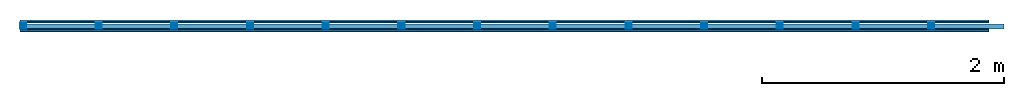
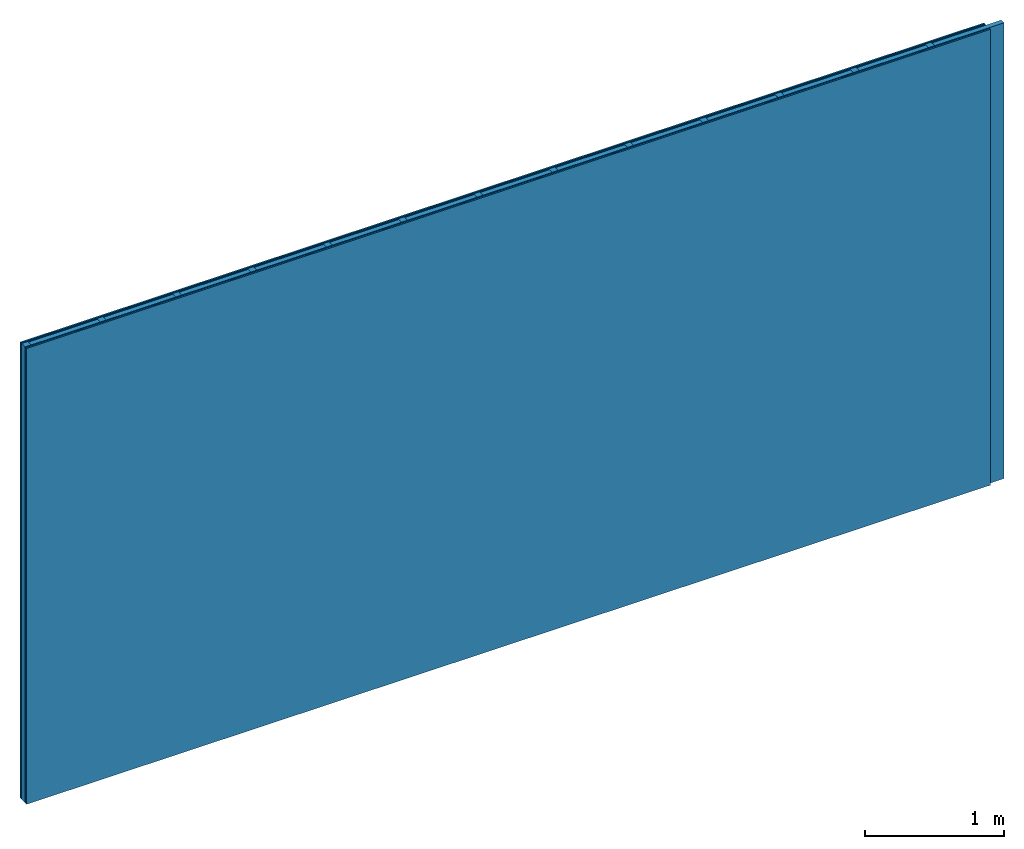
# One storey: 4 plates, 2 members, 1 element without a shape of its own.
"""IFC4 building model written with IfcOpenShell, lengths in metres."""

from ifc_helpers import new_model, si_unit, derived_unit, direction, frame, frame_2d, origin, origin_with_axes, place, context, project, spatial, rectangle, extrude, material, layer, layer_set, type_object, element, aggregate, save


model = new_model("IFC4")

# Units and contexts
plan_context = context("Plan", 3, precision=1e-05, world=origin(), true_north=direction((0.0, 1.0)))
model_context = context("Model", 3, precision=1e-05, world=origin(), true_north=direction((0.0, 1.0)))
ifc_project = project(units=[si_unit("LENGTHUNIT", "METRE"), derived_unit("SOUNDPRESSUREUNIT", [(si_unit("PRESSUREUNIT", "PASCAL", prefix="MICRO"), 0)]), si_unit("ENERGYUNIT", "JOULE", prefix="MEGA"), si_unit("MASSUNIT", "GRAM", prefix="KILO"), derived_unit("THERMALTRANSMITTANCEUNIT", [(si_unit("POWERUNIT", "WATT"), 1), (si_unit("AREAUNIT", "SQUARE_METRE"), -1), (si_unit("THERMODYNAMICTEMPERATUREUNIT", "KELVIN"), -1)]), derived_unit("AREADENSITYUNIT", [(si_unit("MASSUNIT", "GRAM", prefix="KILO"), 1), (si_unit("AREAUNIT", "SQUARE_METRE"), -1)]), derived_unit("USERDEFINED", [(si_unit("ENERGYUNIT", "JOULE", prefix="MEGA"), 1), (si_unit("AREAUNIT", "SQUARE_METRE"), -1)])], contexts=[plan_context, model_context])

# Site, building, storey
site = spatial("IfcSite", under=ifc_project)
building_placement = place(None, origin())
building = spatial("IfcBuilding", under=site, at=building_placement)
storey_placement = place(building_placement, origin())
storey = spatial("IfcBuildingStorey", under=building, at=storey_placement)

# Wall, members, plates
ifc_material_1 = material(Name="joints", Category="04.017")
ifc_layer_1 = layer(ifc_material_1, 0.0, Name="Surface")
ifc_material_2 = material(Name="Plasterboard type A", Category="03.008")
ifc_layer_2 = layer(ifc_material_2, 0.0125, Name="2nd layer")
ifc_material_3 = material(Name="Phone Twin Star", Category="03.013")
ifc_layer_3 = layer(ifc_material_3, 0.01, Name="1st layer")
ifc_material_4 = material(Name="of the art")
ifc_layer_4 = layer(ifc_material_4, 0.0, Name="Bond")
ifc_layer_5 = layer(None, 0.05, Name="Support")
ifc_layer_6 = layer(ifc_material_4, 0.0, Name="Bond")
ifc_layer_7 = layer(ifc_material_3, 0.01, Name="1st layer")
ifc_layer_8 = layer(ifc_material_2, 0.0125, Name="2nd layer")
ifc_layer_9 = layer(ifc_material_1, 0.0, Name="Surface")
ifc_layer_set = layer_set([ifc_layer_1, ifc_layer_2, ifc_layer_3, ifc_layer_4, ifc_layer_5, ifc_layer_6, ifc_layer_7, ifc_layer_8, ifc_layer_9])
wall_type = type_object("IfcWallType", Name="C0460", PredefinedType="NOTDEFINED", material=ifc_layer_set)
wall_placement = place(None, frame((0.0, 0.0, 0.0), z_axis=(0.0, -1.0, 0.0), x_axis=(1.0, 0.0, 0.0)))
wall = element("IfcWall", 1, at=wall_placement, inside=storey, type_object=wall_type, material=ifc_layer_set, Name="Wall #1")
ifc_material_5 = material()
member_1_placement = place(wall_placement, origin())
member_1 = element("IfcMember", 2, at=member_1_placement, material=ifc_material_5, Name="Support", context=plan_context, shape_type="SweptSolid", body=[
    extrude(rectangle(XDim=0.05, YDim=0.05, at=frame_2d((0.025, 0.025), x_axis=(1.0, 0.0))), frame((0.0, 4.0, 0.0225), z_axis=(0.0, -1.0, 0.0), x_axis=(1.0, 0.0, 0.0)), (0.0, 0.0, 1.0), 4.0),
    extrude(rectangle(XDim=0.05, YDim=0.05, at=frame_2d((0.025, 0.025), x_axis=(1.0, 0.0))), frame((0.625, 4.0, 0.0225), z_axis=(0.0, -1.0, 0.0), x_axis=(1.0, 0.0, 0.0)), (0.0, 0.0, 1.0), 4.0),
    extrude(rectangle(XDim=0.05, YDim=0.05, at=frame_2d((0.025, 0.025), x_axis=(1.0, 0.0))), frame((1.25, 4.0, 0.0225), z_axis=(0.0, -1.0, 0.0), x_axis=(1.0, 0.0, 0.0)), (0.0, 0.0, 1.0), 4.0),
    extrude(rectangle(XDim=0.05, YDim=0.05, at=frame_2d((0.025, 0.025), x_axis=(1.0, 0.0))), frame((1.875, 4.0, 0.0225), z_axis=(0.0, -1.0, 0.0), x_axis=(1.0, 0.0, 0.0)), (0.0, 0.0, 1.0), 4.0),
    extrude(rectangle(XDim=0.05, YDim=0.05, at=frame_2d((0.025, 0.025), x_axis=(1.0, 0.0))), frame((2.5, 4.0, 0.0225), z_axis=(0.0, -1.0, 0.0), x_axis=(1.0, 0.0, 0.0)), (0.0, 0.0, 1.0), 4.0),
    extrude(rectangle(XDim=0.05, YDim=0.05, at=frame_2d((0.025, 0.025), x_axis=(1.0, 0.0))), frame((3.125, 4.0, 0.0225), z_axis=(0.0, -1.0, 0.0), x_axis=(1.0, 0.0, 0.0)), (0.0, 0.0, 1.0), 4.0),
    extrude(rectangle(XDim=0.05, YDim=0.05, at=frame_2d((0.025, 0.025), x_axis=(1.0, 0.0))), frame((3.75, 4.0, 0.0225), z_axis=(0.0, -1.0, 0.0), x_axis=(1.0, 0.0, 0.0)), (0.0, 0.0, 1.0), 4.0),
    extrude(rectangle(XDim=0.05, YDim=0.05, at=frame_2d((0.025, 0.025), x_axis=(1.0, 0.0))), frame((4.375, 4.0, 0.0225), z_axis=(0.0, -1.0, 0.0), x_axis=(1.0, 0.0, 0.0)), (0.0, 0.0, 1.0), 4.0),
    extrude(rectangle(XDim=0.05, YDim=0.05, at=frame_2d((0.025, 0.025), x_axis=(1.0, 0.0))), frame((5.0, 4.0, 0.0225), z_axis=(0.0, -1.0, 0.0), x_axis=(1.0, 0.0, 0.0)), (0.0, 0.0, 1.0), 4.0),
    extrude(rectangle(XDim=0.05, YDim=0.05, at=frame_2d((0.025, 0.025), x_axis=(1.0, 0.0))), frame((5.625, 4.0, 0.0225), z_axis=(0.0, -1.0, 0.0), x_axis=(1.0, 0.0, 0.0)), (0.0, 0.0, 1.0), 4.0),
    extrude(rectangle(XDim=0.05, YDim=0.05, at=frame_2d((0.025, 0.025), x_axis=(1.0, 0.0))), frame((6.25, 4.0, 0.0225), z_axis=(0.0, -1.0, 0.0), x_axis=(1.0, 0.0, 0.0)), (0.0, 0.0, 1.0), 4.0),
    extrude(rectangle(XDim=0.05, YDim=0.05, at=frame_2d((0.025, 0.025), x_axis=(1.0, 0.0))), frame((6.875, 4.0, 0.0225), z_axis=(0.0, -1.0, 0.0), x_axis=(1.0, 0.0, 0.0)), (0.0, 0.0, 1.0), 4.0),
    extrude(rectangle(XDim=0.05, YDim=0.05, at=frame_2d((0.025, 0.025), x_axis=(1.0, 0.0))), frame((7.5, 4.0, 0.0225), z_axis=(0.0, -1.0, 0.0), x_axis=(1.0, 0.0, 0.0)), (0.0, 0.0, 1.0), 4.0),
])
ifc_material_6 = material()
member_2_placement = place(wall_placement, origin())
member_2 = element("IfcMember", 3, at=member_2_placement, material=ifc_material_6, Name="Cavity", context=plan_context, shape_type="SweptSolid", body=[
    extrude(rectangle(XDim=0.575, YDim=0.04, at=frame_2d((0.2875, 0.02), x_axis=(1.0, 0.0))), frame((0.05, 4.0, 0.0325), z_axis=(0.0, -1.0, 0.0), x_axis=(1.0, 0.0, 0.0)), (0.0, 0.0, 1.0), 4.0),
    extrude(rectangle(XDim=0.575, YDim=0.04, at=frame_2d((0.2875, 0.02), x_axis=(1.0, 0.0))), frame((0.675, 4.0, 0.0325), z_axis=(0.0, -1.0, 0.0), x_axis=(1.0, 0.0, 0.0)), (0.0, 0.0, 1.0), 4.0),
    extrude(rectangle(XDim=0.575, YDim=0.04, at=frame_2d((0.2875, 0.02), x_axis=(1.0, 0.0))), frame((1.3, 4.0, 0.0325), z_axis=(0.0, -1.0, 0.0), x_axis=(1.0, 0.0, 0.0)), (0.0, 0.0, 1.0), 4.0),
    extrude(rectangle(XDim=0.575, YDim=0.04, at=frame_2d((0.2875, 0.02), x_axis=(1.0, 0.0))), frame((1.925, 4.0, 0.0325), z_axis=(0.0, -1.0, 0.0), x_axis=(1.0, 0.0, 0.0)), (0.0, 0.0, 1.0), 4.0),
    extrude(rectangle(XDim=0.575, YDim=0.04, at=frame_2d((0.2875, 0.02), x_axis=(1.0, 0.0))), frame((2.55, 4.0, 0.0325), z_axis=(0.0, -1.0, 0.0), x_axis=(1.0, 0.0, 0.0)), (0.0, 0.0, 1.0), 4.0),
    extrude(rectangle(XDim=0.575, YDim=0.04, at=frame_2d((0.2875, 0.02), x_axis=(1.0, 0.0))), frame((3.175, 4.0, 0.0325), z_axis=(0.0, -1.0, 0.0), x_axis=(1.0, 0.0, 0.0)), (0.0, 0.0, 1.0), 4.0),
    extrude(rectangle(XDim=0.575, YDim=0.04, at=frame_2d((0.2875, 0.02), x_axis=(1.0, 0.0))), frame((3.8, 4.0, 0.0325), z_axis=(0.0, -1.0, 0.0), x_axis=(1.0, 0.0, 0.0)), (0.0, 0.0, 1.0), 4.0),
    extrude(rectangle(XDim=0.575, YDim=0.04, at=frame_2d((0.2875, 0.02), x_axis=(1.0, 0.0))), frame((4.425, 4.0, 0.0325), z_axis=(0.0, -1.0, 0.0), x_axis=(1.0, 0.0, 0.0)), (0.0, 0.0, 1.0), 4.0),
    extrude(rectangle(XDim=0.575, YDim=0.04, at=frame_2d((0.2875, 0.02), x_axis=(1.0, 0.0))), frame((5.05, 4.0, 0.0325), z_axis=(0.0, -1.0, 0.0), x_axis=(1.0, 0.0, 0.0)), (0.0, 0.0, 1.0), 4.0),
    extrude(rectangle(XDim=0.575, YDim=0.04, at=frame_2d((0.2875, 0.02), x_axis=(1.0, 0.0))), frame((5.675, 4.0, 0.0325), z_axis=(0.0, -1.0, 0.0), x_axis=(1.0, 0.0, 0.0)), (0.0, 0.0, 1.0), 4.0),
    extrude(rectangle(XDim=0.575, YDim=0.04, at=frame_2d((0.2875, 0.02), x_axis=(1.0, 0.0))), frame((6.3, 4.0, 0.0325), z_axis=(0.0, -1.0, 0.0), x_axis=(1.0, 0.0, 0.0)), (0.0, 0.0, 1.0), 4.0),
    extrude(rectangle(XDim=0.575, YDim=0.04, at=frame_2d((0.2875, 0.02), x_axis=(1.0, 0.0))), frame((6.925, 4.0, 0.0325), z_axis=(0.0, -1.0, 0.0), x_axis=(1.0, 0.0, 0.0)), (0.0, 0.0, 1.0), 4.0),
    extrude(rectangle(XDim=0.575, YDim=0.04, at=frame_2d((0.2875, 0.02), x_axis=(1.0, 0.0))), frame((7.55, 4.0, 0.0325), z_axis=(0.0, -1.0, 0.0), x_axis=(1.0, 0.0, 0.0)), (0.0, 0.0, 1.0), 4.0),
])
plate_1_placement = place(wall_placement, origin())
plate_1 = element("IfcPlate", 4, at=plate_1_placement, material=ifc_material_2, Name="2nd layer", context=plan_context, shape_type="SweptSolid", body=[
    extrude(rectangle(XDim=8.0, YDim=4.0, at=frame_2d((4.0, 2.0), x_axis=(1.0, 0.0))), origin_with_axes(), (0.0, 0.0, 1.0), 0.0125),
])
plate_2_placement = place(wall_placement, origin())
plate_2 = element("IfcPlate", 5, at=plate_2_placement, material=ifc_material_3, Name="1st layer", context=plan_context, shape_type="SweptSolid", body=[
    extrude(rectangle(XDim=8.0, YDim=4.0, at=frame_2d((4.0, 2.0), x_axis=(1.0, 0.0))), frame((0.0, 0.0, 0.0125), z_axis=(0.0, 0.0, 1.0), x_axis=(1.0, 0.0, 0.0)), (0.0, 0.0, 1.0), 0.01),
])
plate_3_placement = place(wall_placement, origin())
plate_3 = element("IfcPlate", 6, at=plate_3_placement, material=ifc_material_3, Name="1st layer", context=plan_context, shape_type="SweptSolid", body=[
    extrude(rectangle(XDim=8.0, YDim=4.0, at=frame_2d((4.0, 2.0), x_axis=(1.0, 0.0))), frame((0.0, 0.0, 0.0725), z_axis=(0.0, 0.0, 1.0), x_axis=(1.0, 0.0, 0.0)), (0.0, 0.0, 1.0), 0.01),
])
plate_4_placement = place(wall_placement, origin())
plate_4 = element("IfcPlate", 7, at=plate_4_placement, material=ifc_material_2, Name="2nd layer", context=plan_context, shape_type="SweptSolid", body=[
    extrude(rectangle(XDim=8.0, YDim=4.0, at=frame_2d((4.0, 2.0), x_axis=(1.0, 0.0))), frame((0.0, 0.0, 0.0825), z_axis=(0.0, 0.0, 1.0), x_axis=(1.0, 0.0, 0.0)), (0.0, 0.0, 1.0), 0.0125),
])
aggregate(wall, [plate_1, plate_2, member_1, member_2, plate_3, plate_4])

save(model, "model.ifc")
